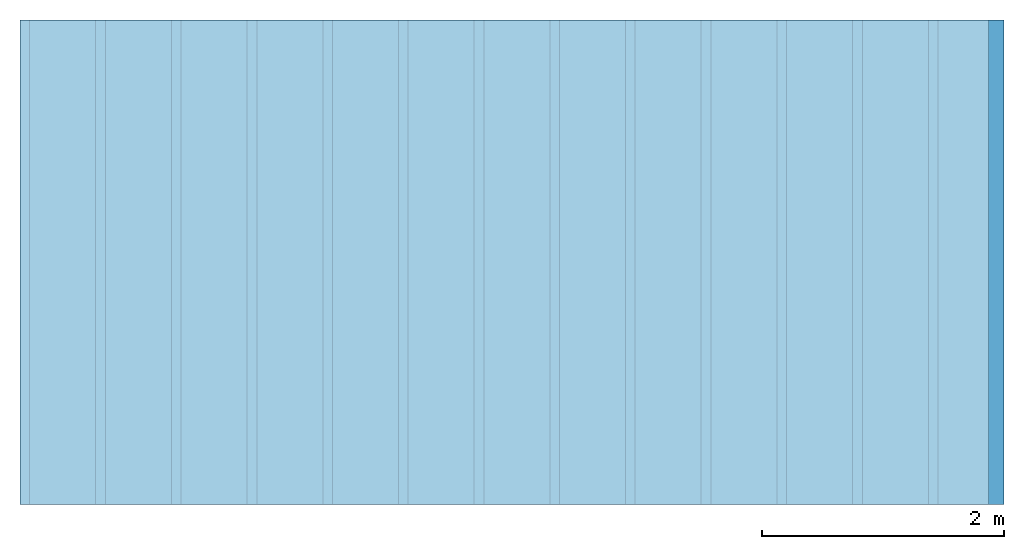
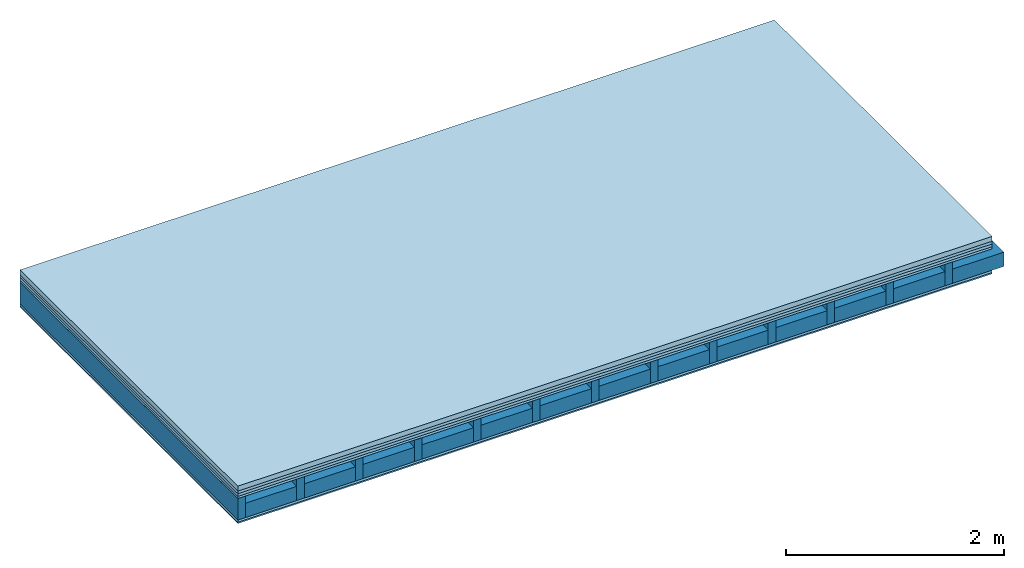
# One storey: 6 plates, 2 members, 1 element without a shape of its own.
"""IFC4 building model written with IfcOpenShell, lengths in metres."""

from ifc_helpers import new_model, si_unit, derived_unit, direction, frame, frame_2d, origin, origin_with_axes, place, context, project, spatial, rectangle, extrude, material, layer, layer_set, type_object, element, aggregate, save


model = new_model("IFC4")

# Units and contexts
plan_context = context("Plan", 3, precision=1e-05, world=origin(), true_north=direction((0.0, 1.0)))
model_context = context("Model", 3, precision=1e-05, world=origin(), true_north=direction((0.0, 1.0)))
ifc_project = project(units=[si_unit("LENGTHUNIT", "METRE"), derived_unit("SOUNDPRESSUREUNIT", [(si_unit("PRESSUREUNIT", "PASCAL", prefix="MICRO"), 0)]), si_unit("ENERGYUNIT", "JOULE", prefix="MEGA"), si_unit("MASSUNIT", "GRAM", prefix="KILO"), derived_unit("THERMALTRANSMITTANCEUNIT", [(si_unit("POWERUNIT", "WATT"), 1), (si_unit("AREAUNIT", "SQUARE_METRE"), -1), (si_unit("THERMODYNAMICTEMPERATUREUNIT", "KELVIN"), -1)]), derived_unit("AREADENSITYUNIT", [(si_unit("MASSUNIT", "GRAM", prefix="KILO"), 1), (si_unit("AREAUNIT", "SQUARE_METRE"), -1)]), derived_unit("USERDEFINED", [(si_unit("ENERGYUNIT", "JOULE", prefix="MEGA"), 1), (si_unit("AREAUNIT", "SQUARE_METRE"), -1)])], contexts=[plan_context, model_context])

# Site, building, storey
site = spatial("IfcSite", under=ifc_project)
building_placement = place(None, origin())
building = spatial("IfcBuilding", under=site, at=building_placement)
storey_placement = place(building_placement, origin())
storey = spatial("IfcBuildingStorey", under=building, at=storey_placement)

# Slab, members, plates
ifc_material_1 = material(Category="04.005")
ifc_layer_1 = layer(ifc_material_1, 0.055, Name="On-material")
ifc_material_2 = material()
ifc_layer_2 = layer(ifc_material_2, 0.03, Name="Impact sound insulation")
ifc_material_3 = material()
ifc_layer_3 = layer(ifc_material_3, 0.03, Name="Additional insulation")
ifc_material_4 = material(Category="07.001")
ifc_layer_4 = layer(ifc_material_4, 0.025, Name="Sub-floor")
ifc_material_5 = material(Name="Rigid, of the art")
ifc_layer_5 = layer(ifc_material_5, 0.0, Name="Bond")
ifc_layer_6 = layer(None, 0.24, Name="Supporting structure")
ifc_layer_7 = layer(ifc_material_5, 0.0, Name="Bond")
ifc_layer_8 = layer(ifc_material_4, 0.025, Name="Lower layer 1")
ifc_material_6 = material(Category="03.007")
ifc_layer_9 = layer(ifc_material_6, 0.015, Name="Lower 2nd layer")
ifc_layer_set = layer_set([ifc_layer_1, ifc_layer_2, ifc_layer_3, ifc_layer_4, ifc_layer_5, ifc_layer_6, ifc_layer_7, ifc_layer_8, ifc_layer_9])
slab_type = type_object("IfcSlabType", Name="A0457", PredefinedType="NOTDEFINED", material=ifc_layer_set)
slab_placement = place(None, frame((0.0, 0.0, 0.0), z_axis=(0.0, 0.0, -1.0), x_axis=(1.0, 0.0, 0.0)))
slab = element("IfcSlab", 1, at=slab_placement, inside=storey, type_object=slab_type, material=ifc_layer_set, Name="Slab #1")
ifc_material_7 = material()
member_1_placement = place(slab_placement, origin())
member_1 = element("IfcMember", 2, at=member_1_placement, material=ifc_material_7, Name="Supporting structure", context=plan_context, shape_type="SweptSolid", body=[
    extrude(rectangle(XDim=0.08, YDim=0.24, at=frame_2d((0.04, 0.12), x_axis=(1.0, 0.0))), frame((0.0, 4.0, 0.14), z_axis=(0.0, -1.0, 0.0), x_axis=(1.0, 0.0, 0.0)), (0.0, 0.0, 1.0), 4.0),
    extrude(rectangle(XDim=0.08, YDim=0.24, at=frame_2d((0.04, 0.12), x_axis=(1.0, 0.0))), frame((0.625, 4.0, 0.14), z_axis=(0.0, -1.0, 0.0), x_axis=(1.0, 0.0, 0.0)), (0.0, 0.0, 1.0), 4.0),
    extrude(rectangle(XDim=0.08, YDim=0.24, at=frame_2d((0.04, 0.12), x_axis=(1.0, 0.0))), frame((1.25, 4.0, 0.14), z_axis=(0.0, -1.0, 0.0), x_axis=(1.0, 0.0, 0.0)), (0.0, 0.0, 1.0), 4.0),
    extrude(rectangle(XDim=0.08, YDim=0.24, at=frame_2d((0.04, 0.12), x_axis=(1.0, 0.0))), frame((1.875, 4.0, 0.14), z_axis=(0.0, -1.0, 0.0), x_axis=(1.0, 0.0, 0.0)), (0.0, 0.0, 1.0), 4.0),
    extrude(rectangle(XDim=0.08, YDim=0.24, at=frame_2d((0.04, 0.12), x_axis=(1.0, 0.0))), frame((2.5, 4.0, 0.14), z_axis=(0.0, -1.0, 0.0), x_axis=(1.0, 0.0, 0.0)), (0.0, 0.0, 1.0), 4.0),
    extrude(rectangle(XDim=0.08, YDim=0.24, at=frame_2d((0.04, 0.12), x_axis=(1.0, 0.0))), frame((3.125, 4.0, 0.14), z_axis=(0.0, -1.0, 0.0), x_axis=(1.0, 0.0, 0.0)), (0.0, 0.0, 1.0), 4.0),
    extrude(rectangle(XDim=0.08, YDim=0.24, at=frame_2d((0.04, 0.12), x_axis=(1.0, 0.0))), frame((3.75, 4.0, 0.14), z_axis=(0.0, -1.0, 0.0), x_axis=(1.0, 0.0, 0.0)), (0.0, 0.0, 1.0), 4.0),
    extrude(rectangle(XDim=0.08, YDim=0.24, at=frame_2d((0.04, 0.12), x_axis=(1.0, 0.0))), frame((4.375, 4.0, 0.14), z_axis=(0.0, -1.0, 0.0), x_axis=(1.0, 0.0, 0.0)), (0.0, 0.0, 1.0), 4.0),
    extrude(rectangle(XDim=0.08, YDim=0.24, at=frame_2d((0.04, 0.12), x_axis=(1.0, 0.0))), frame((5.0, 4.0, 0.14), z_axis=(0.0, -1.0, 0.0), x_axis=(1.0, 0.0, 0.0)), (0.0, 0.0, 1.0), 4.0),
    extrude(rectangle(XDim=0.08, YDim=0.24, at=frame_2d((0.04, 0.12), x_axis=(1.0, 0.0))), frame((5.625, 4.0, 0.14), z_axis=(0.0, -1.0, 0.0), x_axis=(1.0, 0.0, 0.0)), (0.0, 0.0, 1.0), 4.0),
    extrude(rectangle(XDim=0.08, YDim=0.24, at=frame_2d((0.04, 0.12), x_axis=(1.0, 0.0))), frame((6.25, 4.0, 0.14), z_axis=(0.0, -1.0, 0.0), x_axis=(1.0, 0.0, 0.0)), (0.0, 0.0, 1.0), 4.0),
    extrude(rectangle(XDim=0.08, YDim=0.24, at=frame_2d((0.04, 0.12), x_axis=(1.0, 0.0))), frame((6.875, 4.0, 0.14), z_axis=(0.0, -1.0, 0.0), x_axis=(1.0, 0.0, 0.0)), (0.0, 0.0, 1.0), 4.0),
    extrude(rectangle(XDim=0.08, YDim=0.24, at=frame_2d((0.04, 0.12), x_axis=(1.0, 0.0))), frame((7.5, 4.0, 0.14), z_axis=(0.0, -1.0, 0.0), x_axis=(1.0, 0.0, 0.0)), (0.0, 0.0, 1.0), 4.0),
])
ifc_material_8 = material()
member_2_placement = place(slab_placement, origin())
member_2 = element("IfcMember", 3, at=member_2_placement, material=ifc_material_8, Name="in supporting structure", context=plan_context, shape_type="SweptSolid", body=[
    extrude(rectangle(XDim=0.545, YDim=0.16, at=frame_2d((0.2725, 0.08), x_axis=(1.0, 0.0))), frame((0.08, 4.0, 0.22), z_axis=(0.0, -1.0, 0.0), x_axis=(1.0, 0.0, 0.0)), (0.0, 0.0, 1.0), 4.0),
    extrude(rectangle(XDim=0.545, YDim=0.16, at=frame_2d((0.2725, 0.08), x_axis=(1.0, 0.0))), frame((0.705, 4.0, 0.22), z_axis=(0.0, -1.0, 0.0), x_axis=(1.0, 0.0, 0.0)), (0.0, 0.0, 1.0), 4.0),
    extrude(rectangle(XDim=0.545, YDim=0.16, at=frame_2d((0.2725, 0.08), x_axis=(1.0, 0.0))), frame((1.33, 4.0, 0.22), z_axis=(0.0, -1.0, 0.0), x_axis=(1.0, 0.0, 0.0)), (0.0, 0.0, 1.0), 4.0),
    extrude(rectangle(XDim=0.545, YDim=0.16, at=frame_2d((0.2725, 0.08), x_axis=(1.0, 0.0))), frame((1.955, 4.0, 0.22), z_axis=(0.0, -1.0, 0.0), x_axis=(1.0, 0.0, 0.0)), (0.0, 0.0, 1.0), 4.0),
    extrude(rectangle(XDim=0.545, YDim=0.16, at=frame_2d((0.2725, 0.08), x_axis=(1.0, 0.0))), frame((2.58, 4.0, 0.22), z_axis=(0.0, -1.0, 0.0), x_axis=(1.0, 0.0, 0.0)), (0.0, 0.0, 1.0), 4.0),
    extrude(rectangle(XDim=0.545, YDim=0.16, at=frame_2d((0.2725, 0.08), x_axis=(1.0, 0.0))), frame((3.205, 4.0, 0.22), z_axis=(0.0, -1.0, 0.0), x_axis=(1.0, 0.0, 0.0)), (0.0, 0.0, 1.0), 4.0),
    extrude(rectangle(XDim=0.545, YDim=0.16, at=frame_2d((0.2725, 0.08), x_axis=(1.0, 0.0))), frame((3.83, 4.0, 0.22), z_axis=(0.0, -1.0, 0.0), x_axis=(1.0, 0.0, 0.0)), (0.0, 0.0, 1.0), 4.0),
    extrude(rectangle(XDim=0.545, YDim=0.16, at=frame_2d((0.2725, 0.08), x_axis=(1.0, 0.0))), frame((4.455, 4.0, 0.22), z_axis=(0.0, -1.0, 0.0), x_axis=(1.0, 0.0, 0.0)), (0.0, 0.0, 1.0), 4.0),
    extrude(rectangle(XDim=0.545, YDim=0.16, at=frame_2d((0.2725, 0.08), x_axis=(1.0, 0.0))), frame((5.08, 4.0, 0.22), z_axis=(0.0, -1.0, 0.0), x_axis=(1.0, 0.0, 0.0)), (0.0, 0.0, 1.0), 4.0),
    extrude(rectangle(XDim=0.545, YDim=0.16, at=frame_2d((0.2725, 0.08), x_axis=(1.0, 0.0))), frame((5.705, 4.0, 0.22), z_axis=(0.0, -1.0, 0.0), x_axis=(1.0, 0.0, 0.0)), (0.0, 0.0, 1.0), 4.0),
    extrude(rectangle(XDim=0.545, YDim=0.16, at=frame_2d((0.2725, 0.08), x_axis=(1.0, 0.0))), frame((6.33, 4.0, 0.22), z_axis=(0.0, -1.0, 0.0), x_axis=(1.0, 0.0, 0.0)), (0.0, 0.0, 1.0), 4.0),
    extrude(rectangle(XDim=0.545, YDim=0.16, at=frame_2d((0.2725, 0.08), x_axis=(1.0, 0.0))), frame((6.955, 4.0, 0.22), z_axis=(0.0, -1.0, 0.0), x_axis=(1.0, 0.0, 0.0)), (0.0, 0.0, 1.0), 4.0),
    extrude(rectangle(XDim=0.545, YDim=0.16, at=frame_2d((0.2725, 0.08), x_axis=(1.0, 0.0))), frame((7.58, 4.0, 0.22), z_axis=(0.0, -1.0, 0.0), x_axis=(1.0, 0.0, 0.0)), (0.0, 0.0, 1.0), 4.0),
])
plate_1_placement = place(slab_placement, origin())
plate_1 = element("IfcPlate", 4, at=plate_1_placement, material=ifc_material_1, Name="On-material", context=plan_context, shape_type="SweptSolid", body=[
    extrude(rectangle(XDim=8.0, YDim=4.0, at=frame_2d((4.0, 2.0), x_axis=(1.0, 0.0))), origin_with_axes(), (0.0, 0.0, 1.0), 0.055),
])
plate_2_placement = place(slab_placement, origin())
plate_2 = element("IfcPlate", 5, at=plate_2_placement, material=ifc_material_2, Name="Impact sound insulation", context=plan_context, shape_type="SweptSolid", body=[
    extrude(rectangle(XDim=8.0, YDim=4.0, at=frame_2d((4.0, 2.0), x_axis=(1.0, 0.0))), frame((0.0, 0.0, 0.055), z_axis=(0.0, 0.0, 1.0), x_axis=(1.0, 0.0, 0.0)), (0.0, 0.0, 1.0), 0.03),
])
plate_3_placement = place(slab_placement, origin())
plate_3 = element("IfcPlate", 6, at=plate_3_placement, material=ifc_material_3, Name="Additional insulation", context=plan_context, shape_type="SweptSolid", body=[
    extrude(rectangle(XDim=8.0, YDim=4.0, at=frame_2d((4.0, 2.0), x_axis=(1.0, 0.0))), frame((0.0, 0.0, 0.085), z_axis=(0.0, 0.0, 1.0), x_axis=(1.0, 0.0, 0.0)), (0.0, 0.0, 1.0), 0.03),
])
plate_4_placement = place(slab_placement, origin())
plate_4 = element("IfcPlate", 7, at=plate_4_placement, material=ifc_material_4, Name="Sub-floor", context=plan_context, shape_type="SweptSolid", body=[
    extrude(rectangle(XDim=8.0, YDim=4.0, at=frame_2d((4.0, 2.0), x_axis=(1.0, 0.0))), frame((0.0, 0.0, 0.115), z_axis=(0.0, 0.0, 1.0), x_axis=(1.0, 0.0, 0.0)), (0.0, 0.0, 1.0), 0.025),
])
plate_5_placement = place(slab_placement, origin())
plate_5 = element("IfcPlate", 8, at=plate_5_placement, material=ifc_material_4, Name="Lower layer 1", context=plan_context, shape_type="SweptSolid", body=[
    extrude(rectangle(XDim=8.0, YDim=4.0, at=frame_2d((4.0, 2.0), x_axis=(1.0, 0.0))), frame((0.0, 0.0, 0.38), z_axis=(0.0, 0.0, 1.0), x_axis=(1.0, 0.0, 0.0)), (0.0, 0.0, 1.0), 0.025),
])
plate_6_placement = place(slab_placement, origin())
plate_6 = element("IfcPlate", 9, at=plate_6_placement, material=ifc_material_6, Name="Lower 2nd layer", context=plan_context, shape_type="SweptSolid", body=[
    extrude(rectangle(XDim=8.0, YDim=4.0, at=frame_2d((4.0, 2.0), x_axis=(1.0, 0.0))), frame((0.0, 0.0, 0.405), z_axis=(0.0, 0.0, 1.0), x_axis=(1.0, 0.0, 0.0)), (0.0, 0.0, 1.0), 0.015),
])
aggregate(slab, [plate_1, plate_2, plate_3, plate_4, member_1, member_2, plate_5, plate_6])

save(model, "model.ifc")
